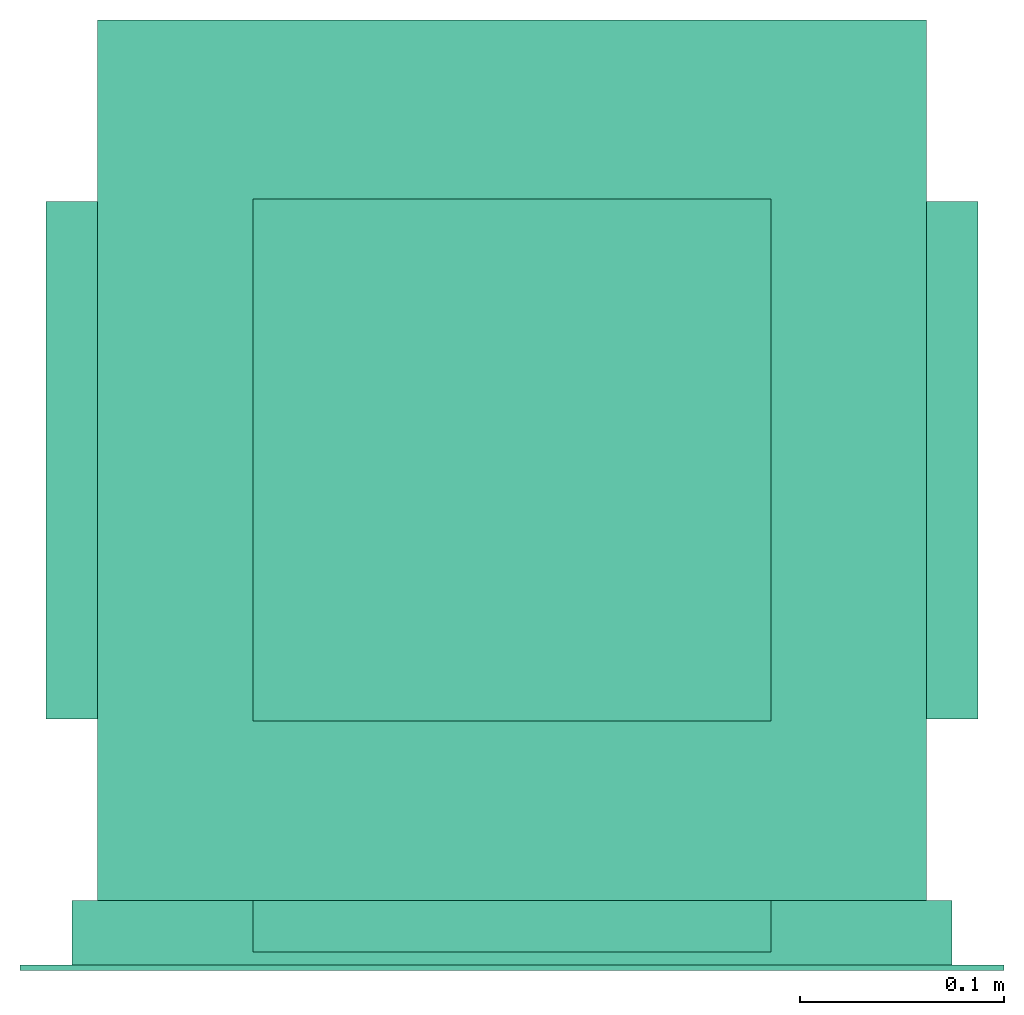
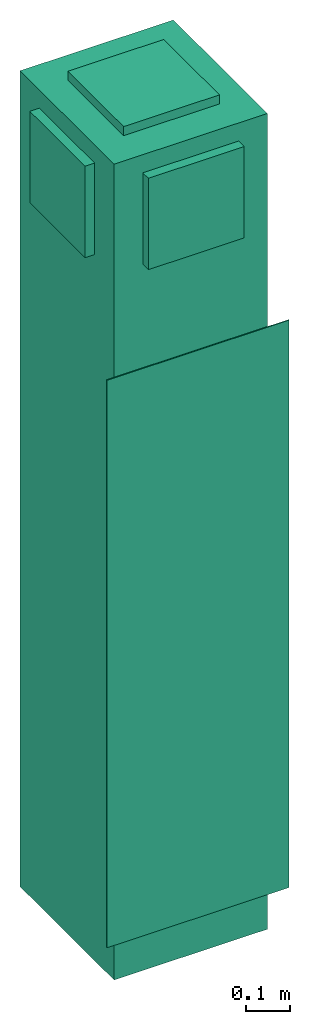
# One storey: 1 energy conversion device.
"""IFC2X3 building model written with IfcOpenShell, lengths in metres."""

from ifc_helpers import new_model, entity, si_unit, converted_unit, origin, origin_with_axes, place, context, subcontext, project, spatial, faceted_brep, type_object, element, save


model = new_model("IFC2X3")

# Units and contexts
model_context = context("Model", 3, precision=1e-05, world=origin())
body_context = subcontext(model_context, "Body", "Model", "MODEL_VIEW")
ifc_project = project(units=[si_unit("LENGTHUNIT", "METRE"), si_unit("AREAUNIT", "SQUARE_METRE"), si_unit("VOLUMEUNIT", "CUBIC_METRE"), converted_unit("PLANEANGLEUNIT", "DEGREE", entity("IfcPlaneAngleMeasure", 0.0174532925199433), si_unit("PLANEANGLEUNIT", "RADIAN"), dimensions=[0, 0, 0, 0, 0, 0, 0]), si_unit("SOLIDANGLEUNIT", "STERADIAN"), si_unit("MASSUNIT", "GRAM"), si_unit("TIMEUNIT", "SECOND"), si_unit("THERMODYNAMICTEMPERATUREUNIT", "DEGREE_CELSIUS"), si_unit("LUMINOUSINTENSITYUNIT", "LUMEN")], contexts=[model_context])

# Site, building, storey
site_placement = place(None, origin_with_axes())
site = spatial("IfcSite", under=ifc_project, at=site_placement, CompositionType="ELEMENT")
building_placement = place(site_placement, origin_with_axes())
building = spatial("IfcBuilding", under=site, at=building_placement, CompositionType="ELEMENT")
storey_placement = place(building_placement, origin_with_axes())
storey = spatial("IfcBuildingStorey", under=building, at=storey_placement, CompositionType="ELEMENT", Elevation=0.0)

# Energy conversion device
heat_exchanger_type = type_object("IfcHeatExchangerType", Name="Vertical Stack Hybrid Water-Cooled Air Conditioner", PredefinedType="NOTDEFINED")
energy_conversion_device_placement = place(storey_placement, origin_with_axes())
element("IfcEnergyConversionDevice", 1, at=energy_conversion_device_placement, inside=storey, type_object=heat_exchanger_type, Name="Vertical Stack Hybrid Water-Cooled Air Conditioner", context=body_context, shape_type="Brep", body=[
    faceted_brep([(-0.1778, -0.254, 1.22679401321411), (-0.1778, -0.254, 0.625196722412109), (0.1778, -0.254, 0.625196722412109), (0.1778, -0.254, 1.22679401321411), (-0.1778, -0.287654995155333, 0.625196722412109), (0.1778, -0.287654995155333, 0.625196722412109), (0.1778, -0.287654995155333, 1.22679401321411), (0.2032, 0.144145004844665, 0.0), (0.2032, -0.287654995155333, 0.0), (-0.2032, -0.287654995155333, 0.0), (-0.2032, 0.144145004844665, 0.0), (0.2032, 0.144145004844665, 2.286), (-0.2032, 0.144145004844665, 2.286), (-0.2032, -0.287654995155333, 2.286), (0.2032, -0.287654995155333, 2.286), (-0.127, 0.144145004844665, 1.97921039276123), (0.127, 0.144145004844665, 1.97921039276123), (-0.127, 0.144145004844665, 2.2352), (0.127, 0.144145004844665, 2.2352), (-0.1778, -0.287654995155333, 1.22679401321411)], [[[0, 1, 2]], [[2, 3, 0]], [[4, 5, 2]], [[2, 1, 4]], [[5, 6, 3]], [[3, 2, 5]], [[7, 8, 9]], [[9, 10, 7]], [[11, 12, 13]], [[13, 14, 11]], [[12, 15, 10]], [[16, 7, 10]], [[10, 15, 16]], [[17, 12, 11]], [[11, 18, 17]], [[15, 12, 17]], [[11, 7, 16]], [[16, 18, 11]], [[11, 14, 8]], [[8, 7, 11]], [[13, 12, 10]], [[10, 9, 13]], [[6, 5, 8]], [[4, 9, 8]], [[8, 5, 4]], [[6, 14, 13]], [[13, 19, 6]], [[8, 14, 6]], [[19, 9, 4]], [[9, 19, 13]], [[19, 4, 1]], [[1, 0, 19]], [[3, 6, 19]], [[19, 0, 3]], [[18, 16, 15]], [[15, 17, 18]]]),
    faceted_brep([(-0.127, -0.199749762439728, 2.3114), (-0.127, 0.0562397660732269, 2.3114), (-0.127, 0.0562397660732269, 2.286), (-0.127, -0.199749762439728, 2.286), (0.127, 0.0562397660732269, 2.3114), (0.127, 0.0562397660732269, 2.286), (0.127, -0.199749762439728, 2.3114), (0.127, -0.199749762439728, 2.286)], [[[0, 1, 2]], [[2, 3, 0]], [[1, 4, 5]], [[5, 2, 1]], [[4, 6, 7]], [[7, 5, 4]], [[6, 0, 3]], [[3, 7, 6]], [[4, 1, 0]], [[0, 6, 4]], [[5, 3, 2]], [[3, 5, 7]]]),
    faceted_brep([(0.2032, 0.0552449987888335, 2.2352), (0.2032, -0.198754995155335, 2.2352), (0.2286, -0.198754995155335, 2.2352), (0.2286, 0.0552449987888335, 2.2352), (0.2032, -0.198754995155335, 1.97921039276123), (0.2286, -0.198754995155335, 1.97921039276123), (0.2032, 0.0552449987888335, 1.97921039276123), (0.2286, 0.0552449987888335, 1.97921039276123)], [[[0, 1, 2]], [[2, 3, 0]], [[1, 4, 5]], [[5, 2, 1]], [[4, 6, 7]], [[7, 5, 4]], [[6, 0, 3]], [[3, 7, 6]], [[6, 4, 1]], [[1, 0, 6]], [[7, 2, 5]], [[2, 7, 3]]]),
    faceted_brep([(-0.2032, 0.0552449987888335, 2.2352), (-0.2032, 0.0552449987888335, 1.97921039276123), (-0.2286, 0.0552449987888335, 1.97921039276123), (-0.2286, 0.0552449987888335, 2.2352), (-0.2032, -0.198754995155335, 1.97921039276123), (-0.2286, -0.198754995155335, 1.97921039276123), (-0.2032, -0.198754995155335, 2.2352), (-0.2286, -0.198754995155335, 2.2352)], [[[0, 1, 2]], [[2, 3, 0]], [[1, 4, 5]], [[5, 2, 1]], [[4, 6, 7]], [[7, 5, 4]], [[6, 0, 3]], [[3, 7, 6]], [[4, 1, 0]], [[0, 6, 4]], [[5, 3, 2]], [[3, 5, 7]]]),
    faceted_brep([(-0.127, -0.287654995155333, 2.2352), (-0.127, -0.287654995155333, 1.97921039276123), (-0.127, -0.313054995155334, 1.97921039276123), (-0.127, -0.313054995155334, 2.2352), (0.127, -0.287654995155333, 1.97921039276123), (0.127, -0.313054995155334, 1.97921039276123), (0.127, -0.287654995155333, 2.2352), (0.127, -0.313054995155334, 2.2352)], [[[0, 1, 2]], [[2, 3, 0]], [[1, 4, 5]], [[5, 2, 1]], [[4, 6, 7]], [[7, 5, 4]], [[6, 0, 3]], [[3, 7, 6]], [[4, 1, 0]], [[0, 6, 4]], [[5, 3, 2]], [[3, 5, 7]]]),
    faceted_brep([(-0.2159, -0.319404995155333, 0.149860002422333), (-0.2159, -0.319404995155333, 1.6891), (-0.2159, -0.287654995155333, 1.6891), (-0.2159, -0.287654995155333, 0.149860002422333), (0.2159, -0.319404995155333, 0.149860002422333), (0.2159, -0.287654995155333, 0.149860002422333), (0.2159, -0.319404995155333, 1.6891), (0.2159, -0.287654995155333, 1.6891), (-0.2413, -0.319404995155333, 1.7145), (-0.2413, -0.319404995155333, 0.124460002422333), (0.2413, -0.319404995155333, 0.124460002422333), (0.2413, -0.319404995155333, 1.7145), (-0.2413, -0.321945004844666, 0.124460002422333), (-0.2413, -0.321945004844666, 1.7145), (0.2413, -0.321945004844666, 0.124460002422333), (0.2413, -0.321945004844666, 1.7145)], [[[0, 1, 2]], [[2, 3, 0]], [[4, 0, 3]], [[3, 5, 4]], [[6, 4, 5]], [[5, 7, 6]], [[6, 7, 2]], [[2, 1, 6]], [[2, 7, 5]], [[5, 3, 2]], [[8, 0, 9]], [[9, 0, 4]], [[4, 10, 9]], [[1, 8, 11]], [[11, 6, 1]], [[0, 8, 1]], [[11, 10, 4]], [[4, 6, 11]], [[12, 13, 8]], [[8, 9, 12]], [[10, 14, 12]], [[12, 9, 10]], [[15, 14, 10]], [[10, 11, 15]], [[15, 11, 8]], [[8, 13, 15]], [[13, 12, 14]], [[14, 15, 13]]]),
])

save(model, "model.ifc")
